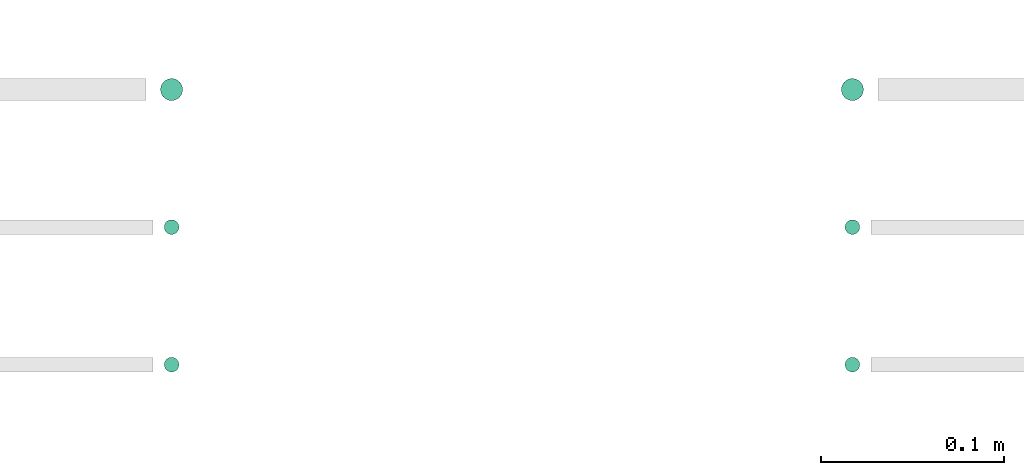
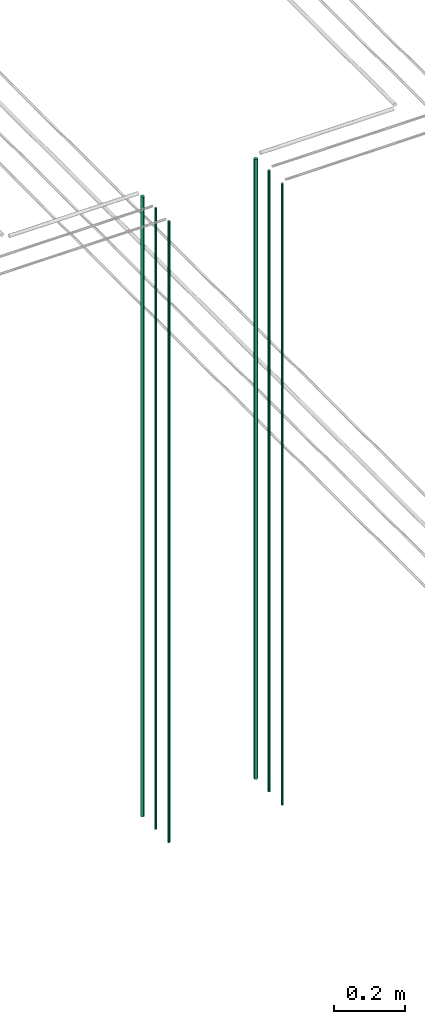
# One storey, part 7 of 331: 6 flow segments.
"""IFC2X3 building model written with IfcOpenShell, lengths in millimetres."""

import ifcopenshell
import ifcopenshell.guid

model = None  # the IFC model being written
_history = None  # IfcOwnerHistory: only IFC2X3 demands one
_inside = {}  # id of a spatial element -> (the spatial element, [elements in it])
_under = {}  # id of a project, library or spatial element -> (it, [spatial elements below it])
_declared = {}  # id of a project -> (the project, [libraries it declares])
_typed = {}  # id of a type object -> (the type object, [elements of that type])
_made_of = {}  # id of a material, layer set ... -> (it, [elements and type objects made of it])


def new_model(schema):
    """Start an empty IFC model of exactly this schema.

    Asked for "IFC4X3", IfcOpenShell would pick the latest addendum, in which some entities
    have other attributes; the version numbers below select the first issue.
    IFC2X3 requires an IfcOwnerHistory on every rooted entity: one is made here for all.
    """
    global model, _history
    if schema == "IFC4X3":
        model = ifcopenshell.file(schema_version=(4, 3, 0, 0))
    else:
        model = ifcopenshell.file(schema=schema)
    _inside.clear()
    _under.clear()
    _declared.clear()
    _typed.clear()
    _made_of.clear()
    _history = None
    if model.schema == "IFC2X3":
        org = make("IfcOrganization", Name="unknown")
        user = make(
            "IfcPersonAndOrganization",
            ThePerson=make("IfcPerson", FamilyName="unknown"),
            TheOrganization=org,
        )
        app = make(
            "IfcApplication",
            ApplicationDeveloper=org,
            Version="unknown",
            ApplicationFullName="unknown",
            ApplicationIdentifier="unknown",
        )
        _history = make(
            "IfcOwnerHistory",
            OwningUser=user,
            OwningApplication=app,
            ChangeAction="ADDED",
            CreationDate=0,
        )
    return model


def make(cls, **values):
    """One entity of the class cls with the attributes given. An attribute that is None is left unset."""
    return model.create_entity(
        cls, **{name: value for name, value in values.items() if value is not None}
    )


def entity(cls, *values):
    """Any entity or typed value of the class cls, its attributes in the order of the schema. None: left unset."""
    e = model.create_entity(cls)
    for i, value in enumerate(values):
        if value is not None:
            e[i] = value
    return e


def rooted(cls, **values):
    """An entity with a GlobalId (a new one), such as an element, a storey or a relation."""
    return make(cls, GlobalId=ifcopenshell.guid.new(), OwnerHistory=_history, **values)


def si_unit(unit_type, name, prefix=None):
    """IfcSIUnit, for example si_unit("LENGTHUNIT", "METRE", prefix="MILLI")."""
    return make("IfcSIUnit", UnitType=unit_type, Prefix=prefix, Name=name)


def converted_unit(unit_type, name, factor, base, dimensions=None, offset=None):
    """IfcConversionBasedUnit, such as the inch: factor (a typed value) times the base unit."""
    return make(
        "IfcConversionBasedUnit"
        if offset is None
        else "IfcConversionBasedUnitWithOffset",
        ConversionOffset=offset,
        Dimensions=None
        if dimensions is None
        else entity("IfcDimensionalExponents", *dimensions),
        UnitType=unit_type,
        Name=name,
        ConversionFactor=make(
            "IfcMeasureWithUnit", ValueComponent=factor, UnitComponent=base
        ),
    )


def derived_unit(unit_type, elements):
    """IfcDerivedUnit: a product of units, each with its exponent."""
    return make(
        "IfcDerivedUnit",
        Elements=[
            make("IfcDerivedUnitElement", Unit=unit, Exponent=power)
            for unit, power in elements
        ],
        UnitType=unit_type,
    )


def assignment(units):
    """IfcUnitAssignment: the units of a project."""
    return None if units is None else make("IfcUnitAssignment", Units=units)


def point(xyz):
    """IfcCartesianPoint."""
    return None if xyz is None else make("IfcCartesianPoint", Coordinates=xyz)


def direction(xyz):
    """IfcDirection."""
    return None if xyz is None else make("IfcDirection", DirectionRatios=xyz)


def frame(location, z_axis=None, x_axis=None):
    """IfcAxis2Placement3D, a coordinate frame: its origin and axes. An axis left out is left unset."""
    return make(
        "IfcAxis2Placement3D",
        Location=point(location),
        Axis=direction(z_axis),
        RefDirection=direction(x_axis),
    )


def frame_2d(location, x_axis=None):
    """IfcAxis2Placement2D, a coordinate frame in the plane: its origin and x axis."""
    return make(
        "IfcAxis2Placement2D", Location=point(location), RefDirection=direction(x_axis)
    )


def origin():
    """The frame at (0, 0, 0) with its axes left unset."""
    return frame((0.0, 0.0, 0.0))


def origin_2d_with_axis():
    """The frame at (0, 0) in the plane with the x axis (1, 0) written out."""
    return frame_2d((0.0, 0.0), x_axis=(1.0, 0.0))


def place(relative_to, where):
    """IfcLocalPlacement: puts the frame where relative to a parent placement (None: the world)."""
    return make(
        "IfcLocalPlacement", PlacementRelTo=relative_to, RelativePlacement=where
    )


def context(
    kind, dimensions, precision=None, world=None, true_north=None, identifier=None
):
    """IfcGeometricRepresentationContext, for example the 3D "Model" context."""
    return make(
        "IfcGeometricRepresentationContext",
        ContextIdentifier=identifier,
        ContextType=kind,
        CoordinateSpaceDimension=dimensions,
        Precision=precision,
        WorldCoordinateSystem=world,
        TrueNorth=true_north,
    )


def subcontext(parent, identifier, kind, view, scale=None):
    """IfcGeometricRepresentationSubContext, for example "Body" below "Model"."""
    return make(
        "IfcGeometricRepresentationSubContext",
        ContextIdentifier=identifier,
        ContextType=kind,
        ParentContext=parent,
        TargetScale=scale,
        TargetView=view,
    )


def project(units=None, contexts=None):
    """IfcProject with its units and contexts."""
    return rooted(
        "IfcProject",
        Name="project",
        RepresentationContexts=contexts,
        UnitsInContext=assignment(units),
    )


def spatial(cls, under=None, at=None, **own):
    """A site, building, storey or space (cls), placed at a placement, below another one or the project."""
    s = rooted(cls, ObjectPlacement=at, **own)
    if under is not None:
        _under.setdefault(under.id(), (under, []))[1].append(s)
    return s


def profile(cls, at=None, kind="AREA", **sizes):
    """A parametric profile (cls). Its sizes go by their IFC names, for example OverallWidth=200.0."""
    return make(cls, ProfileType=kind, Position=at, **sizes)


def circle(**sizes):
    """IfcCircleProfileDef."""
    return profile("IfcCircleProfileDef", **sizes)


def extrude(swept, where, along, depth):
    """IfcExtrudedAreaSolid: the profile swept, set in the frame where, extruded along a direction by depth."""
    return make(
        "IfcExtrudedAreaSolid",
        SweptArea=swept,
        Position=where,
        ExtrudedDirection=direction(along),
        Depth=depth,
    )


def shape(context_of_items, identifier, shape_type, items):
    """IfcShapeRepresentation: the items that make up one representation, for example the "Body"."""
    return make(
        "IfcShapeRepresentation",
        ContextOfItems=context_of_items,
        RepresentationIdentifier=identifier,
        RepresentationType=shape_type,
        Items=items,
    )


def made_of(thing, what):
    """Note that an element or type object is made of a material, layer set ...; save() writes the relation."""
    if what is not None:
        _made_of.setdefault(what.id(), (what, []))[1].append(thing)
    return thing


def type_object(cls, material=None, **own):
    """A type object (cls), such as IfcWallType, which elements share."""
    return made_of(rooted(cls, **own), material)


def element(
    cls,
    number,
    at=None,
    inside=None,
    cuts=None,
    type_object=None,
    material=None,
    context=None,
    identifier="Body",
    shape_type=None,
    held_by="IfcProductDefinitionShape",
    body=None,
    shapes=None,
    **own,
):
    """One element of the class cls, such as IfcWall. Its Tag is "e" and its number.

    at: its placement. inside: the storey or other place that contains it. cuts: it is an
    opening in that element (IfcRelVoidsElement). A single representation is given by context,
    identifier, shape_type and body (its items); several are given by shapes. held_by: the class
    of the entity that holds the representations. save() writes the other relations.
    """
    e = rooted(cls, Tag="e%d" % number, ObjectPlacement=at, **own)
    if body is not None:
        shapes = [shape(context, identifier, shape_type, body)]
    if shapes is not None:
        e.Representation = make(held_by, Representations=shapes)
    if inside is not None:
        _inside.setdefault(inside.id(), (inside, []))[1].append(e)
    if cuts is not None:
        rooted(
            "IfcRelVoidsElement", RelatingBuildingElement=cuts, RelatedOpeningElement=e
        )
    if type_object is not None:
        _typed.setdefault(type_object.id(), (type_object, []))[1].append(e)
    return made_of(e, material)


def aggregate(whole, parts):
    """IfcRelAggregates: a whole, such as a stair, and the parts it consists of."""
    return rooted("IfcRelAggregates", RelatingObject=whole, RelatedObjects=parts)


def save(model, path):
    """Write the relations noted so far, then the file.

    IfcRelAggregates (storeys below a building ...), IfcRelContainedInSpatialStructure (elements
    in a storey), IfcRelDefinesByType, IfcRelAssociatesMaterial and IfcRelDeclares: one each for
    every whole, place, type object, material and project.
    """
    for whole, parts in _under.values():
        aggregate(whole, parts)
    for where, things in _inside.values():
        rooted(
            "IfcRelContainedInSpatialStructure",
            RelatedElements=things,
            RelatingStructure=where,
        )
    for kind, things in _typed.values():
        rooted("IfcRelDefinesByType", RelatedObjects=things, RelatingType=kind)
    for what, things in _made_of.values():
        rooted("IfcRelAssociatesMaterial", RelatedObjects=things, RelatingMaterial=what)
    for by, libraries in _declared.values():
        rooted("IfcRelDeclares", RelatingContext=by, RelatedDefinitions=libraries)
    model.write(path)


model = new_model("IFC2X3")

# Units and contexts
model_context = context("Model", 3, precision=0.01, world=origin(), true_north=direction((6.12303176911189e-17, 1.0)))
body_context = subcontext(model_context, "Body", "Model", "MODEL_VIEW")
ifc_project = project(units=[si_unit("LENGTHUNIT", "METRE", prefix="MILLI"), si_unit("AREAUNIT", "SQUARE_METRE"), si_unit("VOLUMEUNIT", "CUBIC_METRE"), converted_unit("PLANEANGLEUNIT", "DEGREE", entity("IfcRatioMeasure", 0.0174532925199433), si_unit("PLANEANGLEUNIT", "RADIAN"), dimensions=[0, 0, 0, 0, 0, 0, 0]), si_unit("MASSUNIT", "GRAM", prefix="KILO"), derived_unit("MASSDENSITYUNIT", [(si_unit("MASSUNIT", "GRAM", prefix="KILO"), 1), (si_unit("LENGTHUNIT", "METRE"), -3)]), derived_unit("MOMENTOFINERTIAUNIT", [(si_unit("LENGTHUNIT", "METRE"), 4)]), si_unit("TIMEUNIT", "SECOND"), si_unit("FREQUENCYUNIT", "HERTZ"), si_unit("THERMODYNAMICTEMPERATUREUNIT", "DEGREE_CELSIUS"), derived_unit("THERMALTRANSMITTANCEUNIT", [(si_unit("MASSUNIT", "GRAM", prefix="KILO"), 1), (si_unit("THERMODYNAMICTEMPERATUREUNIT", "KELVIN"), -1), (si_unit("TIMEUNIT", "SECOND"), -3)]), derived_unit("VOLUMETRICFLOWRATEUNIT", [(si_unit("LENGTHUNIT", "METRE"), 3), (si_unit("TIMEUNIT", "SECOND"), -1)]), derived_unit("MASSFLOWRATEUNIT", [(si_unit("MASSUNIT", "GRAM", prefix="KILO"), 1), (si_unit("TIMEUNIT", "SECOND"), -1)]), derived_unit("ROTATIONALFREQUENCYUNIT", [(si_unit("TIMEUNIT", "SECOND"), -1)]), si_unit("ELECTRICCURRENTUNIT", "AMPERE"), si_unit("ELECTRICVOLTAGEUNIT", "VOLT"), si_unit("POWERUNIT", "WATT"), si_unit("FORCEUNIT", "NEWTON", prefix="KILO"), si_unit("ILLUMINANCEUNIT", "LUX"), si_unit("LUMINOUSFLUXUNIT", "LUMEN"), si_unit("LUMINOUSINTENSITYUNIT", "CANDELA"), derived_unit("USERDEFINED", [(si_unit("MASSUNIT", "GRAM", prefix="KILO"), -1), (si_unit("LENGTHUNIT", "METRE"), -2), (si_unit("TIMEUNIT", "SECOND"), 3), (si_unit("LUMINOUSFLUXUNIT", "LUMEN"), 1)]), derived_unit("LINEARVELOCITYUNIT", [(si_unit("LENGTHUNIT", "METRE"), 1), (si_unit("TIMEUNIT", "SECOND"), -1)]), si_unit("PRESSUREUNIT", "PASCAL"), derived_unit("USERDEFINED", [(si_unit("LENGTHUNIT", "METRE"), -2), (si_unit("MASSUNIT", "GRAM", prefix="KILO"), 1), (si_unit("TIMEUNIT", "SECOND"), -2)]), derived_unit("LINEARFORCEUNIT", [(si_unit("MASSUNIT", "GRAM", prefix="KILO"), 1), (si_unit("LENGTHUNIT", "METRE"), 1), (si_unit("TIMEUNIT", "SECOND"), -2), (si_unit("LENGTHUNIT", "METRE"), -1)]), derived_unit("PLANARFORCEUNIT", [(si_unit("MASSUNIT", "GRAM", prefix="KILO"), 1), (si_unit("LENGTHUNIT", "METRE"), 1), (si_unit("TIMEUNIT", "SECOND"), -2), (si_unit("LENGTHUNIT", "METRE"), -2)])], contexts=[model_context])

# Site, building, storey
site_placement = place(None, frame((0.0, -0.00077364408347762, 0.0)))
site = spatial("IfcSite", under=ifc_project, at=site_placement, CompositionType="ELEMENT")
building_placement = place(site_placement, origin())
building = spatial("IfcBuilding", under=site, at=building_placement, CompositionType="ELEMENT")
storey_placement = place(building_placement, origin())
storey = spatial("IfcBuildingStorey", under=building, at=storey_placement, CompositionType="ELEMENT", Elevation=0.0)

# Flow segments
pipe_segment_type = type_object("IfcPipeSegmentType", PredefinedType="NOTDEFINED")
flow_segment_1_placement = place(storey_placement, frame((35149.1379388917, 1343.89349484323, 12990.0)))
element("IfcFlowSegment", 1, at=flow_segment_1_placement, inside=storey, type_object=pipe_segment_type, context=body_context, shape_type="SweptSolid", body=[
    extrude(circle(Radius=6.0, at=origin_2d_with_axis()), frame((7.59527223591454, 7.59527223591589, 0.0)), (0.0, 0.0, 1.0), 2146.0),
])
flow_segment_2_placement = place(storey_placement, frame((35151.1379388917, 1270.89349484385, 12990.0)))
element("IfcFlowSegment", 2, at=flow_segment_2_placement, inside=storey, type_object=pipe_segment_type, context=body_context, shape_type="SweptSolid", body=[
    extrude(circle(Radius=4.0, at=origin_2d_with_axis()), frame((5.59527223591499, 5.5952722359158, 0.0)), (0.0, 0.0, 1.0), 2150.00000000001),
])
flow_segment_3_placement = place(storey_placement, frame((35151.1379388917, 1195.8934948434, 12990.0)))
element("IfcFlowSegment", 3, at=flow_segment_3_placement, inside=storey, type_object=pipe_segment_type, context=body_context, shape_type="SweptSolid", body=[
    extrude(circle(Radius=4.0, at=origin_2d_with_axis()), frame((5.59527223591499, 5.59527223591607, 0.0)), (0.0, 0.0, 1.0), 2150.00000000001),
])
flow_segment_4_placement = place(storey_placement, frame((34777.8885865545, 1343.89349484327, 12990.0)))
element("IfcFlowSegment", 4, at=flow_segment_4_placement, inside=storey, type_object=pipe_segment_type, context=body_context, shape_type="SweptSolid", body=[
    extrude(circle(Radius=6.0, at=origin_2d_with_axis()), frame((7.59527223591454, 7.59527223591589, 0.0)), (0.0, 0.0, 1.0), 2146.0),
])
flow_segment_5_placement = place(storey_placement, frame((34779.8885865545, 1270.89349484385, 12990.0)))
element("IfcFlowSegment", 5, at=flow_segment_5_placement, inside=storey, type_object=pipe_segment_type, context=body_context, shape_type="SweptSolid", body=[
    extrude(circle(Radius=4.0, at=origin_2d_with_axis()), frame((5.59527223591499, 5.5952722359158, 0.0)), (0.0, 0.0, 1.0), 2150.00000000001),
])
flow_segment_6_placement = place(storey_placement, frame((34779.8885865545, 1195.89349484343, 12990.0)))
element("IfcFlowSegment", 6, at=flow_segment_6_placement, inside=storey, type_object=pipe_segment_type, context=body_context, shape_type="SweptSolid", body=[
    extrude(circle(Radius=4.0, at=origin_2d_with_axis()), frame((5.59527223591499, 5.59527223591607, 0.0)), (0.0, 0.0, 1.0), 2150.00000000001),
])

save(model, "model.ifc")
